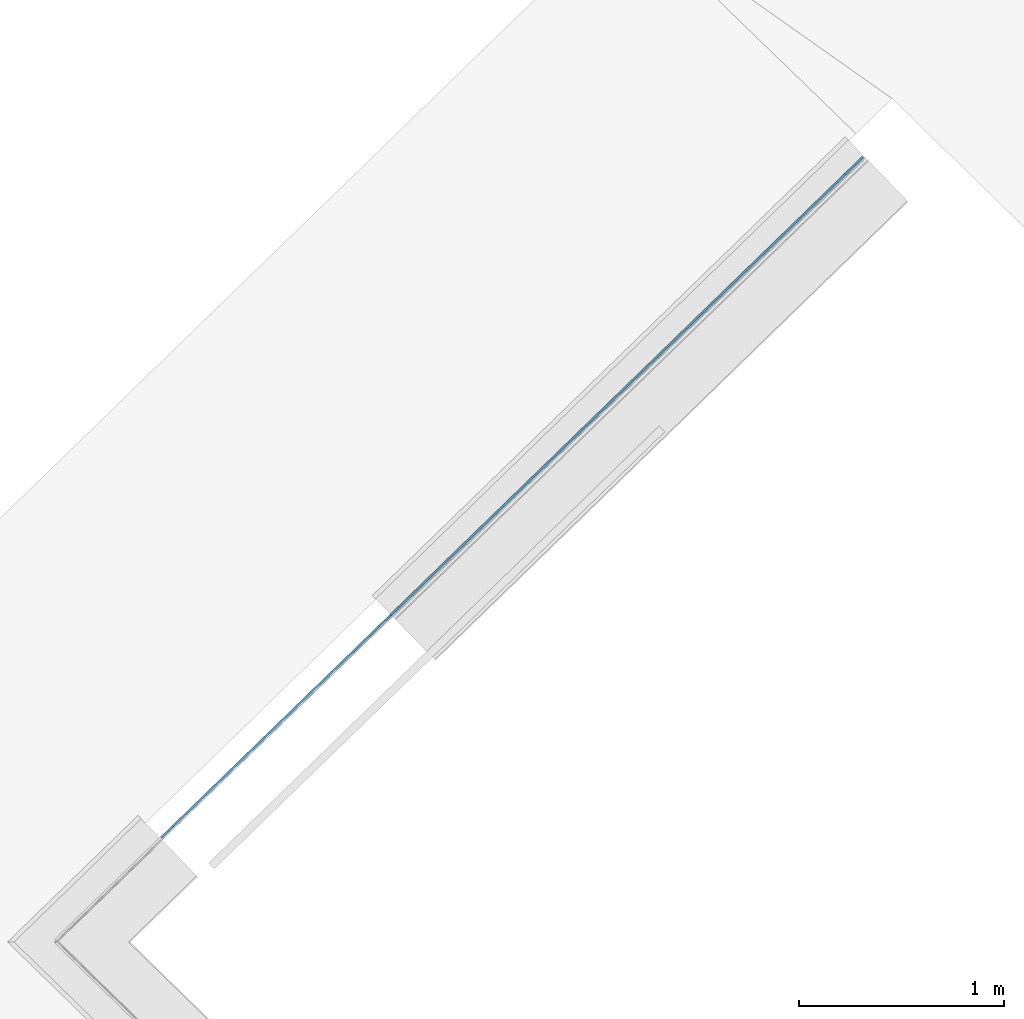
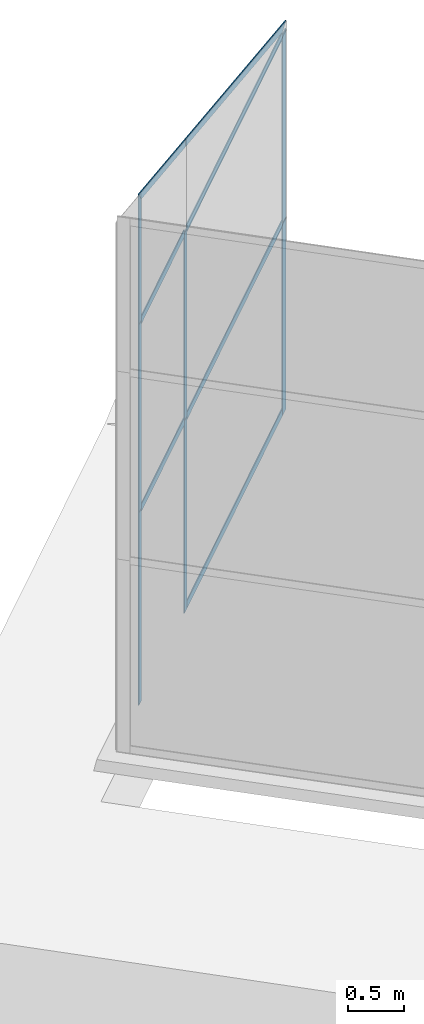
# One storey, part 6 of 13: 14 members, 1 element without a shape of its own.
"""IFC4 building model written with IfcOpenShell, lengths in metres."""

from ifc_helpers import new_model, entity, si_unit, converted_unit, direction, frame, origin, place, context, subcontext, project, spatial, indexed_curve, outline, extrude, source, transform, mapped, material, type_object, type_shapes, element, aggregate, save


model = new_model("IFC4")

# Units and contexts
model_context = context("Model", 3, precision=1e-05, world=origin(), true_north=direction((6.123233995736766e-17, 1.0)))
body_context = subcontext(model_context, "Body", "Model", "MODEL_VIEW")
ifc_project = project(units=[si_unit("LENGTHUNIT", "METRE"), si_unit("AREAUNIT", "SQUARE_METRE"), si_unit("VOLUMEUNIT", "CUBIC_METRE"), converted_unit("PLANEANGLEUNIT", "DEGREE", entity("IfcPlaneAngleMeasure", 0.017453292519943278), si_unit("PLANEANGLEUNIT", "RADIAN"), dimensions=[0, 0, 0, 0, 0, 0, 0])], contexts=[model_context])

# Site, building, storey
site_placement = place(None, frame((0.0, 0.0, 0.0), z_axis=(0.0, 0.0, 1.0), x_axis=(0.7160934825303189, -0.6980043870045516, 0.0)))
site = spatial("IfcSite", under=ifc_project, at=site_placement, CompositionType="ELEMENT")
building_placement = place(site_placement, origin())
building = spatial("IfcBuilding", under=site, at=building_placement, CompositionType="ELEMENT")
storey_placement = place(building_placement, frame((0.0, 0.0, -7.0)))
storey = spatial("IfcBuildingStorey", under=building, at=storey_placement, Name="-7.00 m", CompositionType="ELEMENT", Elevation=-7.000000000000001)

# Curtain wall, members
curtain_wall_type = type_object("IfcCurtainWallType", Name="Facciata continua:Vetrata_1", PredefinedType="NOTDEFINED")
curtain_wall_placement = place(storey_placement, frame((0.0, 0.0, 7.0)))
curtain_wall = element("IfcCurtainWall", 1, at=curtain_wall_placement, inside=storey, type_object=curtain_wall_type, Name="Facciata continua:Vetrata_1", ObjectType="Facciata continua:Vetrata_1", PredefinedType="NOTDEFINED")
ifc_material = material(Name="Acciaio", Category="Metallo")
member_type_1 = type_object("IfcMemberType", Name="Montante rettangolare:Montante rettangolare 3", PredefinedType="MULLION", material=ifc_material)
shared_shape_1 = source(origin(), body_context, "Body", "SweptSolid", [
    extrude(outline(indexed_curve([(-0.06, -0.005000000000000005), (0.06, -0.005000000000000005), (0.06, 0.005000000000000005), (-0.06, 0.005000000000000005), (-0.06, -0.005000000000000005)], self_intersect=False)), frame((-0.06, 0.010000000000000002, -2.030000000000001), z_axis=(0.0, 0.0, 1.0), x_axis=(-1.0, 0.0, 0.0)), (0.0, 0.0, 1.0), 2.030000000000001),
])
type_shapes(member_type_1, [shared_shape_1])
member_1_placement = place(curtain_wall_placement, frame((-27.660170770889117, -1.4926882967088835, -2.829999999999999), z_axis=(0.0, 0.0, 1.0), x_axis=(0.027980069795956325, 0.9996084812036228, 0.0)))
member_1 = element("IfcMember", 2, at=member_1_placement, type_object=member_type_1, material=ifc_material, Name="Montante rettangolare:Montante rettangolare 3", ObjectType="Montante rettangolare:Montante rettangolare 3", PredefinedType="MULLION", context=body_context, shape_type="MappedRepresentation", body=[
    mapped(shared_shape_1, transform((0.0, 0.0, 0.0), scale=1.0)),
])
member_type_2 = type_object("IfcMemberType", Name="Montante rettangolare:Montante rettangolare 3", PredefinedType="MULLION", material=ifc_material)
shared_shape_2 = source(origin(), body_context, "Body", "SweptSolid", [
    extrude(outline(indexed_curve([(-0.06, -0.005000000000000005), (0.06, -0.005000000000000005), (0.06, 0.005000000000000005), (-0.06, 0.005000000000000005), (-0.06, -0.005000000000000005)], self_intersect=False)), frame((-0.06, 0.010000000000000002, -2.080000000000001), z_axis=(0.0, 0.0, 1.0), x_axis=(-1.0, 0.0, 0.0)), (0.0, 0.0, 1.0), 2.080000000000001),
])
type_shapes(member_type_2, [shared_shape_2])
member_2_placement = place(curtain_wall_placement, frame((-27.660170770889117, -1.4926882967088835, -4.86), z_axis=(0.0, 0.0, 1.0), x_axis=(0.027980069795956325, 0.9996084812036228, 0.0)))
member_2 = element("IfcMember", 3, at=member_2_placement, type_object=member_type_2, material=ifc_material, Name="Montante rettangolare:Montante rettangolare 3", ObjectType="Montante rettangolare:Montante rettangolare 3", PredefinedType="MULLION", context=body_context, shape_type="MappedRepresentation", body=[
    mapped(shared_shape_2, transform((0.0, 0.0, 0.0), scale=1.0)),
])
member_type_3 = type_object("IfcMemberType", Name="Montante rettangolare:Montante rettangolare 2", PredefinedType="MULLION", material=ifc_material)
shared_shape_3 = source(origin(), body_context, "Body", "SweptSolid", [
    extrude(outline(indexed_curve([(-0.04, -0.005000000000000001), (0.04, -0.005000000000000001), (0.04, 0.005000000000000001), (-0.04, 0.005000000000000001), (-0.04, -0.005000000000000001)], self_intersect=False)), frame((0.0, 0.009999999999999998, -2.0800000000000005), z_axis=(0.0, 0.0, 1.0), x_axis=(-1.0, 0.0, 0.0)), (0.0, 0.0, 1.0), 2.0800000000000005),
])
type_shapes(member_type_3, [shared_shape_3])
member_3_placement = place(curtain_wall_placement, frame((-27.751099271810016, -4.741175572348033, -6.9399999999999995), z_axis=(0.0, 0.0, -1.0), x_axis=(-0.027980069795956325, -0.9996084812036228, 0.0)))
member_3 = element("IfcMember", 4, at=member_3_placement, type_object=member_type_3, material=ifc_material, Name="Montante rettangolare:Montante rettangolare 2", ObjectType="Montante rettangolare:Montante rettangolare 2", PredefinedType="MULLION", context=body_context, shape_type="MappedRepresentation", body=[
    mapped(shared_shape_3, transform((0.0, 0.0, 0.0), scale=1.0)),
])
member_4_placement = place(curtain_wall_placement, frame((-27.792525994448617, -6.221175572348133, -6.9399999999999995), z_axis=(0.0, 0.0, -1.0), x_axis=(-0.027980069795956325, -0.9996084812036228, 0.0)))
member_4 = element("IfcMember", 5, at=member_4_placement, type_object=member_type_3, material=ifc_material, Name="Montante rettangolare:Montante rettangolare 2", ObjectType="Montante rettangolare:Montante rettangolare 2", PredefinedType="MULLION", context=body_context, shape_type="MappedRepresentation", body=[
    mapped(shared_shape_3, transform((0.0, 0.0, 0.0), scale=1.0)),
])
member_type_4 = type_object("IfcMemberType", Name="Montante rettangolare:Montante rettangolare 2", PredefinedType="MULLION", material=ifc_material)
shared_shape_4 = source(origin(), body_context, "Body", "SweptSolid", [
    extrude(outline(indexed_curve([(-0.04, -0.005000000000000001), (0.04, -0.005000000000000001), (0.04, 0.005000000000000001), (-0.04, 0.005000000000000001), (-0.04, -0.005000000000000001)], self_intersect=False)), frame((0.0, 0.009999999999999998, -2.030000000000001), z_axis=(0.0, 0.0, 1.0), x_axis=(-1.0, 0.0, 0.0)), (0.0, 0.0, 1.0), 2.030000000000001),
])
type_shapes(member_type_4, [shared_shape_4])
member_5_placement = place(curtain_wall_placement, frame((-27.751099271810016, -4.741175572348033, -4.86), z_axis=(0.0, 0.0, -1.0), x_axis=(-0.027980069795956325, -0.9996084812036228, 0.0)))
member_5 = element("IfcMember", 6, at=member_5_placement, type_object=member_type_4, material=ifc_material, Name="Montante rettangolare:Montante rettangolare 2", ObjectType="Montante rettangolare:Montante rettangolare 2", PredefinedType="MULLION", context=body_context, shape_type="MappedRepresentation", body=[
    mapped(shared_shape_4, transform((0.0, 0.0, 0.0), scale=1.0)),
])
member_6_placement = place(curtain_wall_placement, frame((-27.792525994448617, -6.221175572348134, -4.86), z_axis=(0.0, 0.0, -1.0), x_axis=(-0.027980069795956325, -0.9996084812036228, 0.0)))
member_6 = element("IfcMember", 7, at=member_6_placement, type_object=member_type_4, material=ifc_material, Name="Montante rettangolare:Montante rettangolare 2", ObjectType="Montante rettangolare:Montante rettangolare 2", PredefinedType="MULLION", context=body_context, shape_type="MappedRepresentation", body=[
    mapped(shared_shape_4, transform((0.0, 0.0, 0.0), scale=1.0)),
])
member_type_5 = type_object("IfcMemberType", Name="Montante rettangolare:Montante rettangolare 2", PredefinedType="MULLION", material=ifc_material)
shared_shape_5 = source(origin(), body_context, "Body", "SweptSolid", [
    extrude(outline(indexed_curve([(-1.6613076620817275, -0.04), (1.7124424650937136, -0.04), (1.6101728590697415, 0.04), (-1.6613076620817275, 0.04), (-1.6613076620817275, -0.04)], self_intersect=False)), frame((-0.04, 0.004999999999999997, -1.6613076620817278), z_axis=(0.0, 1.0, 0.0), x_axis=(0.0, 0.0, -1.0)), (0.0, 0.0, 1.0), 0.010000000000000002),
])
type_shapes(member_type_5, [shared_shape_5])
member_7_placement = place(curtain_wall_placement, frame((-27.751099271810013, -4.741175572348033, -1.8381540956178817), z_axis=(-0.026951759168075795, -0.9628713310664877, 0.26861199245007045), x_axis=(0.007515782296783864, 0.2685068258060939, 0.9632484609445289)))
member_7 = element("IfcMember", 8, at=member_7_placement, type_object=member_type_5, material=ifc_material, Name="Montante rettangolare:Montante rettangolare 2", ObjectType="Montante rettangolare:Montante rettangolare 2", PredefinedType="MULLION", context=body_context, shape_type="MappedRepresentation", body=[
    mapped(shared_shape_5, transform((0.0, 0.0, 0.0), scale=1.0)),
])
member_type_6 = type_object("IfcMemberType", Name="Montante rettangolare:Montante rettangolare 2", PredefinedType="MULLION", material=ifc_material)
shared_shape_6 = source(origin(), body_context, "Body", "SweptSolid", [
    extrude(outline(indexed_curve([(-0.8156380301555447, -0.04), (0.7629574583659521, -0.04), (0.7629574583659521, 0.04), (-0.7102768865763595, 0.04), (-0.8156380301555447, -0.04)], self_intersect=False)), frame((-0.04, 0.004999999999999997, -0.7741118802349133), z_axis=(0.0, 1.0, 0.0), x_axis=(0.0, 0.0, -1.0)), (0.0, 0.0, 1.0), 0.009999999999999993),
])
type_shapes(member_type_6, [shared_shape_6])
member_8_placement = place(curtain_wall_placement, frame((-27.792525994448614, -6.221175572348134, -1.4252788380424033), z_axis=(-0.026951759168073925, -0.9628713310664874, 0.2686119924500713), x_axis=(0.007515782296783886, 0.26850682580609475, 0.9632484609445285)))
member_8 = element("IfcMember", 9, at=member_8_placement, type_object=member_type_6, material=ifc_material, Name="Montante rettangolare:Montante rettangolare 2", ObjectType="Montante rettangolare:Montante rettangolare 2", PredefinedType="MULLION", context=body_context, shape_type="MappedRepresentation", body=[
    mapped(shared_shape_6, transform((0.0, 0.0, 0.0), scale=1.0)),
])
member_type_7 = type_object("IfcMemberType", Name="Montante rettangolare:Montante rettangolare 2", PredefinedType="MULLION", material=ifc_material)
shared_shape_7 = source(origin(), body_context, "Body", "SweptSolid", [
    extrude(outline(indexed_curve([(-0.04, -0.004999999999999997), (0.04, -0.004999999999999997), (0.04, 0.004999999999999997), (-0.04, 0.004999999999999997), (-0.04, -0.004999999999999997)], self_intersect=False)), frame((-0.04, 0.009999999999999993, -3.089759617613152), z_axis=(0.0, 0.0, 1.0), x_axis=(-1.0, 0.0, 0.0)), (0.0, 0.0, 1.0), 3.089759617613152),
])
type_shapes(member_type_7, [shared_shape_7])
member_9_placement = place(curtain_wall_placement, frame((-27.66352837926463, -1.612641314453318, -6.9399999999999995), z_axis=(0.027980069795956714, 0.9996084812036228, 0.0), x_axis=(0.0, 0.0, -1.0)))
member_9 = element("IfcMember", 10, at=member_9_placement, type_object=member_type_7, material=ifc_material, Name="Montante rettangolare:Montante rettangolare 2", ObjectType="Montante rettangolare:Montante rettangolare 2", PredefinedType="MULLION", context=body_context, shape_type="MappedRepresentation", body=[
    mapped(shared_shape_7, transform((0.0, 0.0, 0.0), scale=1.0)),
])
member_type_8 = type_object("IfcMemberType", Name="Montante rettangolare:Montante rettangolare 2", PredefinedType="MULLION", material=ifc_material)
shared_shape_8 = source(origin(), body_context, "Body", "SweptSolid", [
    extrude(outline(indexed_curve([(-0.04, -0.004999999999999997), (0.04, -0.004999999999999997), (0.04, 0.004999999999999997), (-0.04, 0.004999999999999997), (-0.04, -0.004999999999999997)], self_intersect=False)), frame((0.0, 0.01000000000000001, -3.0897596176131525), z_axis=(0.0, 0.0, 1.0), x_axis=(-1.0, 0.0, 0.0)), (0.0, 0.0, 1.0), 3.089759617613152),
])
type_shapes(member_type_8, [shared_shape_8])
member_10_placement = place(curtain_wall_placement, frame((-27.749980069018182, -4.7011912330998875, -2.829999999999999), z_axis=(-0.027980069795956714, -0.9996084812036228, 0.0), x_axis=(0.0, 0.0, 1.0)))
member_10 = element("IfcMember", 11, at=member_10_placement, type_object=member_type_8, material=ifc_material, Name="Montante rettangolare:Montante rettangolare 2", ObjectType="Montante rettangolare:Montante rettangolare 2", PredefinedType="MULLION", context=body_context, shape_type="MappedRepresentation", body=[
    mapped(shared_shape_8, transform((0.0, 0.0, 0.0), scale=1.0)),
])
member_11_placement = place(curtain_wall_placement, frame((-27.749980069018182, -4.7011912330998875, -4.86), z_axis=(-0.027980069795956714, -0.9996084812036228, 0.0), x_axis=(0.0, 0.0, 1.0)))
member_11 = element("IfcMember", 12, at=member_11_placement, type_object=member_type_8, material=ifc_material, Name="Montante rettangolare:Montante rettangolare 2", ObjectType="Montante rettangolare:Montante rettangolare 2", PredefinedType="MULLION", context=body_context, shape_type="MappedRepresentation", body=[
    mapped(shared_shape_8, transform((0.0, 0.0, 0.0), scale=1.0)),
])
member_type_9 = type_object("IfcMemberType", Name="Montante rettangolare:Montante rettangolare 2", PredefinedType="MULLION", material=ifc_material)
shared_shape_9 = source(origin(), body_context, "Body", "SweptSolid", [
    extrude(outline(indexed_curve([(-0.04, -0.005000000000000001), (0.04, -0.005000000000000001), (0.04, 0.005000000000000001), (-0.04, 0.005000000000000001), (-0.04, -0.005000000000000001)], self_intersect=False)), frame((0.0, 0.009999999999999998, -1.4005796747723083), z_axis=(0.0, 0.0, 1.0), x_axis=(-1.0, 0.0, 0.0)), (0.0, 0.0, 1.0), 1.4005796747723076),
])
type_shapes(member_type_9, [shared_shape_9])
member_12_placement = place(curtain_wall_placement, frame((-27.791406791656783, -6.181191233099987, -2.829999999999999), z_axis=(-0.02798006979595477, -0.9996084812036228, 0.0), x_axis=(0.0, 0.0, 1.0)))
member_12 = element("IfcMember", 13, at=member_12_placement, type_object=member_type_9, material=ifc_material, Name="Montante rettangolare:Montante rettangolare 2", ObjectType="Montante rettangolare:Montante rettangolare 2", PredefinedType="MULLION", context=body_context, shape_type="MappedRepresentation", body=[
    mapped(shared_shape_9, transform((0.0, 0.0, 0.0), scale=1.0)),
])
member_13_placement = place(curtain_wall_placement, frame((-27.791406791656783, -6.181191233099988, -4.86), z_axis=(-0.02798006979595475, -0.9996084812036228, 0.0), x_axis=(0.0, 0.0, 1.0)))
member_13 = element("IfcMember", 14, at=member_13_placement, type_object=member_type_9, material=ifc_material, Name="Montante rettangolare:Montante rettangolare 2", ObjectType="Montante rettangolare:Montante rettangolare 2", PredefinedType="MULLION", context=body_context, shape_type="MappedRepresentation", body=[
    mapped(shared_shape_9, transform((0.0, 0.0, 0.0), scale=1.0)),
])
member_type_10 = type_object("IfcMemberType", Name="Montante rettangolare:Montante rettangolare 2", PredefinedType="MULLION", material=ifc_material)
shared_shape_10 = source(origin(), body_context, "Body", "SweptSolid", [
    extrude(outline(indexed_curve([(-0.6815975060184878, -0.04), (0.7342780778080805, -0.04), (0.6289169342288952, 0.04), (-0.6815975060184878, 0.04), (-0.6815975060184878, -0.04)], self_intersect=False)), frame((0.0, 0.004999999999999997, -0.6815975060184878), z_axis=(0.0, 1.0, 0.0), x_axis=(0.0, 0.0, -1.0)), (0.0, 0.0, 1.0), 0.010000000000000002),
])
type_shapes(member_type_10, [shared_shape_10])
member_14_placement = place(curtain_wall_placement, frame((-27.792525994448617, -6.221175572348133, -2.829999999999999), z_axis=(0.0, 0.0, -1.0), x_axis=(-0.027980069795956325, -0.9996084812036228, 0.0)))
member_14 = element("IfcMember", 15, at=member_14_placement, type_object=member_type_10, material=ifc_material, Name="Montante rettangolare:Montante rettangolare 2", ObjectType="Montante rettangolare:Montante rettangolare 2", PredefinedType="MULLION", context=body_context, shape_type="MappedRepresentation", body=[
    mapped(shared_shape_10, transform((0.0, 0.0, 0.0), scale=1.0)),
])
aggregate(curtain_wall, [member_7, member_8, member_9, member_1, member_2, member_10, member_12, member_11, member_13, member_3, member_4, member_14, member_5, member_6])

save(model, "model.ifc")
